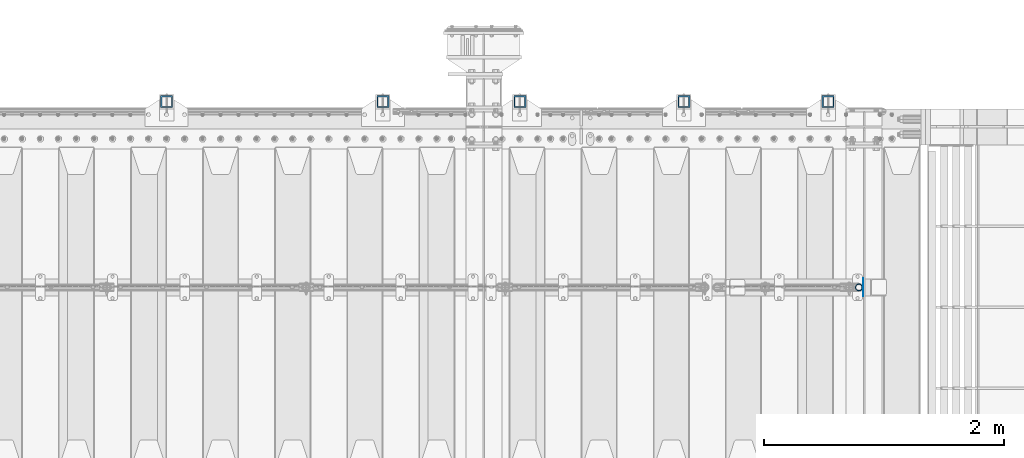
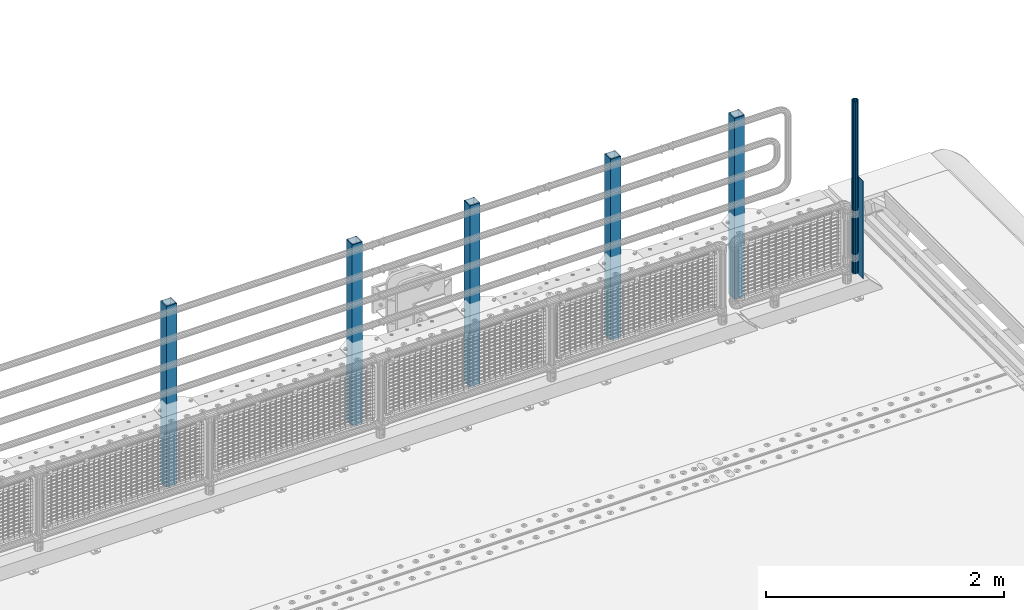
# One storey, part 64 of 240: 7 columns.
"""IFC2X3 building model written with IfcOpenShell, lengths in millimetres."""

from ifc_helpers import new_model, si_unit, frame, origin_with_axes, place, context, subcontext, project, spatial, faceted_brep, material, type_object, element, save


model = new_model("IFC2X3")

# Units and contexts
model_context = context("Model", 3, precision=1e-05, world=origin_with_axes())
body_context = subcontext(model_context, "Body", "Model", "MODEL_VIEW")
ifc_project = project(units=[si_unit("LENGTHUNIT", "METRE", prefix="MILLI"), si_unit("AREAUNIT", "SQUARE_METRE"), si_unit("VOLUMEUNIT", "CUBIC_METRE"), si_unit("MASSUNIT", "GRAM", prefix="KILO"), si_unit("TIMEUNIT", "SECOND"), si_unit("PLANEANGLEUNIT", "RADIAN"), si_unit("SOLIDANGLEUNIT", "STERADIAN"), si_unit("THERMODYNAMICTEMPERATUREUNIT", "DEGREE_CELSIUS"), si_unit("LUMINOUSINTENSITYUNIT", "LUMEN")], contexts=[model_context])

# Site, building, storey
site_placement = place(None, origin_with_axes())
site = spatial("IfcSite", under=ifc_project, at=site_placement, CompositionType="ELEMENT")
building_placement = place(site_placement, origin_with_axes())
building = spatial("IfcBuilding", under=site, at=building_placement, Name="Standard", CompositionType="ELEMENT")
storey_placement = place(building_placement, origin_with_axes())
storey = spatial("IfcBuildingStorey", under=building, at=storey_placement, Name="Undefined", CompositionType="ELEMENT", Elevation=0.0)

# Columns
ifc_material_1 = material(Name="Misc_Undefined")
column_type_1 = type_object("IfcColumnType", PredefinedType="NOTDEFINED")
column_1_placement = place(storey_placement, frame((55961.0, 34664.5, 238.02), z_axis=(-1.0, 0.0, 0.0), x_axis=(0.0, 0.0, 1.0)))
element("IfcColumn", 1, at=column_1_placement, inside=storey, type_object=column_type_1, material=ifc_material_1, context=body_context, shape_type="Brep", body=[
    faceted_brep([(0.0, -25.3499999999985, 0.0), (0.0, -23.4203461491634, 9.70102501045767), (1761.98, -23.4203461491634, 9.70102501045767), (1761.98, -25.3499999999985, 0.0), (0.0, -17.9251569030821, 17.9251569030821), (1761.98, -17.9251569030821, 17.9251569030821), (0.0, -9.70102501045767, 23.4203461491634), (1761.98, -9.70102501045767, 23.4203461491634), (0.0, 0.0, 25.3499999999985), (1761.98, 0.0, 25.3499999999985), (0.0, 9.70102501045767, 23.4203461491634), (1761.98, 9.70102501045767, 23.4203461491634), (0.0, 17.9251569030821, 17.9251569030821), (1761.98, 17.9251569030821, 17.9251569030821), (0.0, 23.4203461491634, 9.70102501045767), (1761.98, 23.4203461491634, 9.70102501045767), (0.0, 25.3499999999985, 0.0), (1761.98, 25.3499999999985, 0.0), (0.0, 23.4203461491634, -9.70102501045767), (1761.98, 23.4203461491634, -9.70102501045767), (0.0, 17.9251569030821, -17.9251569030821), (1761.98, 17.9251569030821, -17.9251569030821), (0.0, 9.70102501045767, -23.4203461491634), (1761.98, 9.70102501045767, -23.4203461491634), (0.0, 0.0, -25.3499999999985), (1761.98, 0.0, -25.3499999999985), (0.0, -9.70102501045767, -23.4203461491634), (1761.98, -9.70102501045767, -23.4203461491634), (0.0, -17.9251569030821, -17.9251569030821), (1761.98, -17.9251569030821, -17.9251569030821), (0.0, -23.4203461491634, -9.70102501045767), (1761.98, -23.4203461491634, -9.70102501045767), (0.0, -30.1500000000015, 0.0), (0.0, -27.8549679052157, -11.5379054858058), (1761.98, -27.8549679052157, -11.5379054858058), (1761.98, -30.1500000000015, 0.0), (0.0, -21.3192694527752, -21.3192694527752), (1761.98, -21.3192694527752, -21.3192694527752), (0.0, -11.5379054858058, -27.8549679052157), (1761.98, -11.5379054858058, -27.8549679052157), (0.0, 0.0, -30.1500000000015), (1761.98, 0.0, -30.1500000000015), (0.0, 11.5379054858058, -27.8549679052157), (1761.98, 11.5379054858058, -27.8549679052157), (0.0, 21.3192694527752, -21.3192694527752), (1761.98, 21.3192694527752, -21.3192694527752), (0.0, 27.8549679052157, -11.5379054858058), (1761.98, 27.8549679052157, -11.5379054858058), (0.0, 30.1500000000015, 0.0), (1761.98, 30.1500000000015, 0.0), (0.0, 27.8549679052157, 11.5379054858058), (1761.98, 27.8549679052157, 11.5379054858058), (0.0, 21.3192694527752, 21.3192694527752), (1761.98, 21.3192694527752, 21.3192694527752), (0.0, 11.5379054858058, 27.8549679052157), (1761.98, 11.5379054858058, 27.8549679052157), (0.0, 0.0, 30.1500000000015), (1761.98, 0.0, 30.1500000000015), (0.0, -11.5379054858058, 27.8549679052157), (1761.98, -11.5379054858058, 27.8549679052157), (0.0, -21.3192694527752, 21.3192694527752), (1761.98, -21.3192694527752, 21.3192694527752), (0.0, -27.8549679052157, 11.5379054858058), (1761.98, -27.8549679052157, 11.5379054858058)], [[[0, 1, 2, 3]], [[1, 4, 5, 2]], [[4, 6, 7, 5]], [[6, 8, 9, 7]], [[8, 10, 11, 9]], [[10, 12, 13, 11]], [[12, 14, 15, 13]], [[14, 16, 17, 15]], [[16, 18, 19, 17]], [[18, 20, 21, 19]], [[20, 22, 23, 21]], [[22, 24, 25, 23]], [[24, 26, 27, 25]], [[26, 28, 29, 27]], [[28, 30, 31, 29]], [[30, 0, 3, 31]], [[32, 33, 34, 35]], [[33, 36, 37, 34]], [[36, 38, 39, 37]], [[38, 40, 41, 39]], [[40, 42, 43, 41]], [[42, 44, 45, 43]], [[44, 46, 47, 45]], [[46, 48, 49, 47]], [[48, 50, 51, 49]], [[50, 52, 53, 51]], [[52, 54, 55, 53]], [[54, 56, 57, 55]], [[56, 58, 59, 57]], [[58, 60, 61, 59]], [[60, 62, 63, 61]], [[62, 32, 35, 63]], [[37, 39, 41, 43, 45, 47, 49, 51, 53, 55, 57, 59, 61, 63, 35, 34], [5, 7, 9, 11, 13, 15, 17, 19, 21, 23, 25, 27, 29, 31, 3, 2]], [[62, 60, 58, 56, 54, 52, 50, 48, 46, 44, 42, 40, 38, 36, 33, 32], [30, 28, 26, 24, 22, 20, 18, 16, 14, 12, 10, 8, 6, 4, 1, 0]]]),
])
column_type_2 = type_object("IfcColumnType", PredefinedType="NOTDEFINED")
column_2_placement = place(storey_placement, frame((55997.5, 34664.5, 200.0), z_axis=(0.0, 1.0, 0.0), x_axis=(0.0, 0.0, 1.0)))
element("IfcColumn", 2, at=column_2_placement, inside=storey, type_object=column_type_2, material=ifc_material_1, context=body_context, shape_type="Brep", body=[
    faceted_brep([(0.0, 1.5, -75.0), (0.0, 1.5, 75.0), (1000.0, 1.5, 75.0), (1000.0, 1.5, -75.0), (0.0, -1.5, 75.0), (1000.0, -1.5, 75.0), (0.0, -1.5, -75.0), (1000.0, -1.5, -75.0)], [[[0, 1, 2, 3]], [[1, 4, 5, 2]], [[4, 6, 7, 5]], [[6, 0, 3, 7]], [[5, 7, 3, 2]], [[6, 4, 1, 0]]]),
])
ifc_material_2 = material()
column_type_3 = type_object("IfcColumnType", PredefinedType="NOTDEFINED")
for number, where, z_axis, x_axis in (
    (3, (55705.0000000001, 36210.0000000002, -844.999999999998), (0.0, -1.0, 0.0), (0.0, 0.0, 1.0)),
    (4, (54505.0000000001, 36210.0000000002, -844.999999999998), (0.0, -1.0, 0.0), (0.0, 0.0, 1.0)),
    (5, (53140.0000000001, 36210.0000000002, -844.999999999998), (0.0, -1.0, 0.0), (0.0, 0.0, 1.0)),
    (6, (52000.0000000001, 36210.0000000002, -844.999999999998), (0.0, -1.0, 0.0), (0.0, 0.0, 1.0)),
    (7, (50200.0000000001, 36210.0000000002, -844.999999999998), (0.0, -1.0, 0.0), (0.0, 0.0, 1.0)),
):
    element("IfcColumn", number, at=place(storey_placement, frame(where, z_axis=z_axis, x_axis=x_axis)), inside=storey, type_object=column_type_3, material=ifc_material_2, context=body_context, shape_type="Brep", body=[
        faceted_brep([(0.0, 40.0, -40.0), (0.0, -40.0, -40.0), (1855.0, -40.0, -40.0), (1855.0, 40.0, -40.0), (0.0, -40.0, 40.0), (1855.0, -40.0, 40.0), (0.0, 40.0, 40.0), (1855.0, 40.0, 40.0), (0.0, 50.0, -50.0), (0.0, 50.0, 50.0), (1855.0, 50.0, 50.0), (1855.0, 50.0, -50.0), (0.0, -50.0, 50.0), (1855.0, -50.0, 50.0), (0.0, -50.0, -50.0), (1855.0, -50.0, -50.0)], [[[0, 1, 2, 3]], [[1, 4, 5, 2]], [[4, 6, 7, 5]], [[6, 0, 3, 7]], [[8, 9, 10, 11]], [[9, 12, 13, 10]], [[12, 14, 15, 13]], [[14, 8, 11, 15]], [[13, 15, 11, 10], [5, 7, 3, 2]], [[14, 12, 9, 8], [6, 4, 1, 0]]]),
    ])

save(model, "model.ifc")
